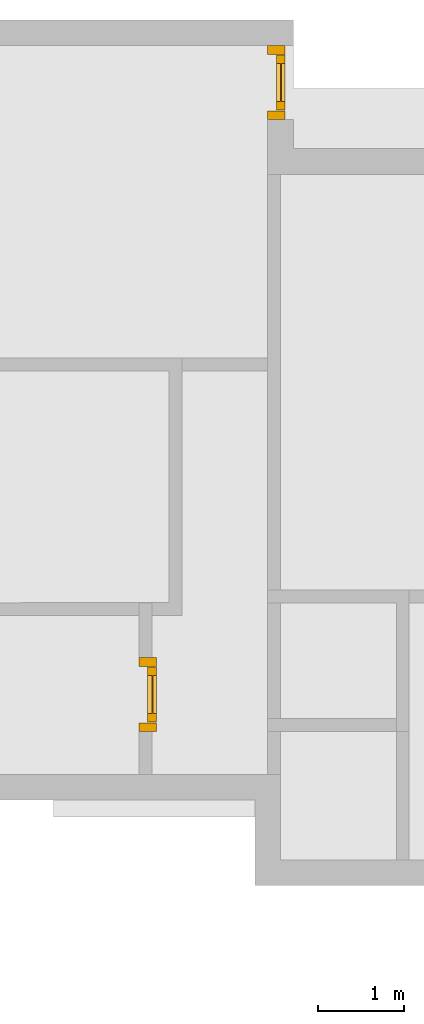
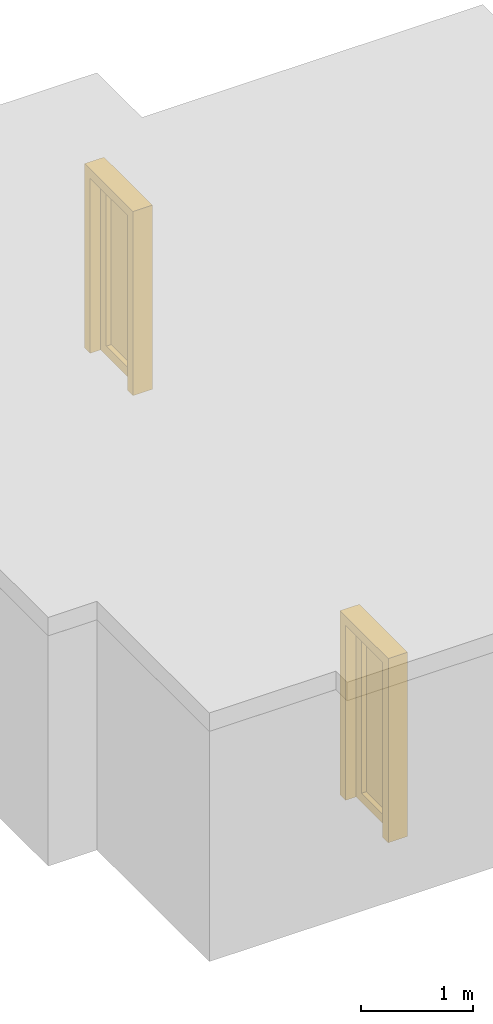
# Not in any storey, part 2 of 3: 2 doors.
"""IFC4 building model written with IfcOpenShell, lengths in metres."""

from ifc_helpers import new_model, entity, si_unit, converted_unit, direction, origin_with_axes, place, context, subcontext, project, spatial, faceted_brep, element, save


model = new_model("IFC4")

# Units and contexts
model_context = context("Model", 3, precision=1e-05, world=origin_with_axes(), true_north=direction((0.0, 1.0)))
body_context = subcontext(model_context, "Body", "Model", "MODEL_VIEW")
ifc_project = project(units=[si_unit("LENGTHUNIT", "METRE"), si_unit("AREAUNIT", "SQUARE_METRE"), si_unit("VOLUMEUNIT", "CUBIC_METRE"), converted_unit("PLANEANGLEUNIT", "DEGREE", entity("IfcPlaneAngleMeasure", 0.017453292519943295), si_unit("PLANEANGLEUNIT", "RADIAN"), dimensions=[0, 0, 0, 0, 0, 0, 0])], contexts=[model_context])

# Building
building = spatial("IfcBuilding", under=ifc_project, Name="Default Building", CompositionType="ELEMENT")

# Doors
placement = place(None, origin_with_axes())
element("IfcDoor", 1, at=placement, inside=building, OperationType="SINGLE_SWING_LEFT", OverallHeight=2000.0, OverallWidth=860.0, PredefinedType="DOOR", context=body_context, shape_type="Brep", body=[
    faceted_brep([(2.5, 6.26, 0.0), (2.5, 6.36, 0.0), (2.7, 6.36, 0.0), (2.7, 6.26, 0.0), (2.5, 6.36, 2.0), (2.5, 6.26, 1.9), (2.5, 5.6, 1.9), (2.5, 5.6, 0.0), (2.5, 5.5, 0.0), (2.5, 5.5, 2.0), (2.7, 6.26, 1.9), (2.7, 6.36, 2.0), (2.7, 5.5, 2.0), (2.7, 5.5, 0.0), (2.7, 5.6, 0.0), (2.7, 5.6, 1.9)], [[[0, 1, 2, 3]], [[4, 1, 0, 5, 6, 7, 8, 9]], [[10, 5, 0, 3]], [[2, 11, 12, 13, 14, 15, 10, 3]], [[4, 11, 2, 1]], [[9, 12, 11, 4]], [[8, 13, 12, 9]], [[8, 7, 14, 13]], [[14, 7, 6, 15]], [[15, 6, 5, 10]]]),
    faceted_brep([(2.6, 6.25, 0.01), (2.7, 6.25, 0.01), (2.7, 5.61, 0.01), (2.6, 5.61, 0.01), (2.6, 6.25, 1.89), (2.7, 6.25, 1.89), (2.7, 5.61, 1.89), (2.6, 5.61, 1.89), (2.6, 5.71, 0.11), (2.6, 6.15, 0.11), (2.6, 6.15, 1.79), (2.6, 5.71, 1.79), (2.7, 6.15, 0.11), (2.7, 5.71, 0.11), (2.7, 5.71, 1.79), (2.7, 6.15, 1.79)], [[[0, 1, 2, 3]], [[4, 5, 1, 0]], [[3, 2, 6, 7]], [[0, 3, 7, 4], [8, 9, 10, 11]], [[2, 1, 5, 6], [12, 13, 14, 15]], [[7, 6, 5, 4]], [[12, 9, 8, 13]], [[13, 8, 11, 14]], [[14, 11, 10, 15]], [[15, 10, 9, 12]]]),
    faceted_brep([(2.65, 6.15, 0.11), (2.66, 6.15, 0.11), (2.66, 5.71, 0.11), (2.65, 5.71, 0.11), (2.66, 5.71, 1.79), (2.65, 5.71, 1.79), (2.66, 6.15, 1.79), (2.65, 6.15, 1.79)], [[[0, 1, 2, 3]], [[3, 2, 4, 5]], [[5, 4, 6, 7]], [[7, 6, 1, 0]], [[0, 3, 5, 7]], [[2, 1, 6, 4]]]),
])
element("IfcDoor", 2, at=placement, inside=building, OperationType="SINGLE_SWING_LEFT", OverallHeight=2000.0, OverallWidth=860.0, PredefinedType="DOOR", context=body_context, shape_type="Brep", body=[
    faceted_brep([(4.0, 13.4, 0.0), (4.0, 13.5, 0.0), (4.2, 13.5, 0.0), (4.2, 13.4, 0.0), (4.0, 13.5, 2.0), (4.0, 13.4, 1.9), (4.0, 12.74, 1.9), (4.0, 12.74, 0.0), (4.0, 12.64, 0.0), (4.0, 12.64, 2.0), (4.2, 13.4, 1.9), (4.2, 13.5, 2.0), (4.2, 12.64, 2.0), (4.2, 12.64, 0.0), (4.2, 12.74, 0.0), (4.2, 12.74, 1.9)], [[[0, 1, 2, 3]], [[4, 1, 0, 5, 6, 7, 8, 9]], [[10, 5, 0, 3]], [[2, 11, 12, 13, 14, 15, 10, 3]], [[4, 11, 2, 1]], [[9, 12, 11, 4]], [[8, 13, 12, 9]], [[8, 7, 14, 13]], [[14, 7, 6, 15]], [[15, 6, 5, 10]]]),
    faceted_brep([(4.1, 13.39, 0.01), (4.2, 13.39, 0.01), (4.2, 12.75, 0.01), (4.1, 12.75, 0.01), (4.1, 13.39, 1.89), (4.2, 13.39, 1.89), (4.2, 12.75, 1.89), (4.1, 12.75, 1.89), (4.1, 12.85, 0.11), (4.1, 13.29, 0.11), (4.1, 13.29, 1.79), (4.1, 12.85, 1.79), (4.2, 13.29, 0.11), (4.2, 12.85, 0.11), (4.2, 12.85, 1.79), (4.2, 13.29, 1.79)], [[[0, 1, 2, 3]], [[4, 5, 1, 0]], [[3, 2, 6, 7]], [[0, 3, 7, 4], [8, 9, 10, 11]], [[2, 1, 5, 6], [12, 13, 14, 15]], [[7, 6, 5, 4]], [[12, 9, 8, 13]], [[13, 8, 11, 14]], [[14, 11, 10, 15]], [[15, 10, 9, 12]]]),
    faceted_brep([(4.15, 13.29, 0.11), (4.16, 13.29, 0.11), (4.16, 12.85, 0.11), (4.15, 12.85, 0.11), (4.16, 12.85, 1.79), (4.15, 12.85, 1.79), (4.16, 13.29, 1.79), (4.15, 13.29, 1.79)], [[[0, 1, 2, 3]], [[3, 2, 4, 5]], [[5, 4, 6, 7]], [[7, 6, 1, 0]], [[0, 3, 5, 7]], [[2, 1, 6, 4]]]),
])

save(model, "model.ifc")
